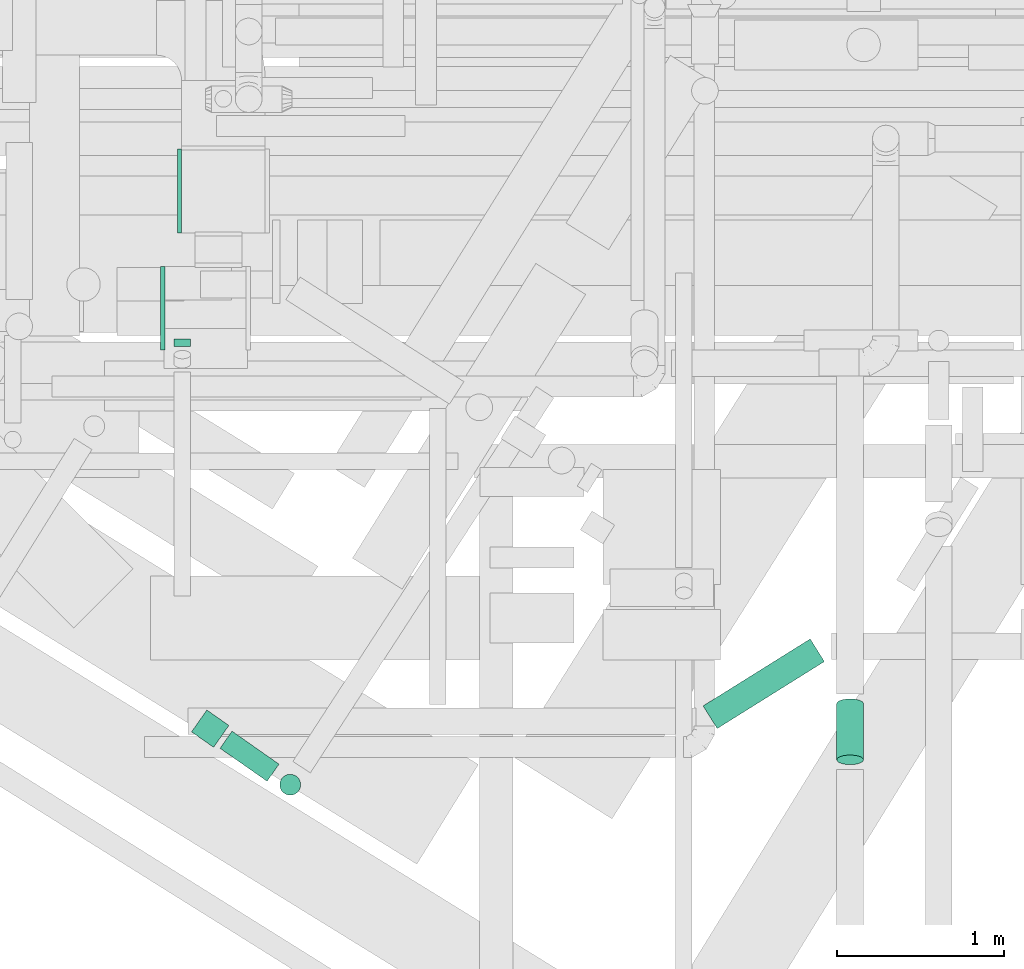
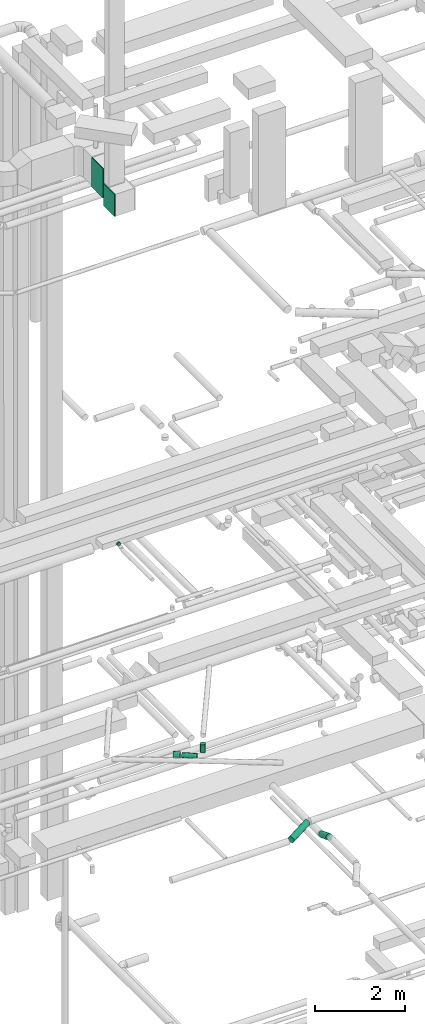
# One storey, part 94 of 337: 6 flow segments, 2 flow fittings.
"""IFC2X3 building model written with IfcOpenShell, lengths in millimetres."""

from ifc_helpers import new_model, entity, si_unit, converted_unit, derived_unit, direction, frame, origin, origin_2d_with_axis, place, context, subcontext, project, spatial, rectangle, circle, extrude, source, transform, mapped, material, type_object, type_shapes, element, save


model = new_model("IFC2X3")

# Units and contexts
model_context = context("Model", 3, precision=0.01, world=origin(), true_north=direction((6.12303176911189e-17, 1.0)))
body_context = subcontext(model_context, "Body", "Model", "MODEL_VIEW")
ifc_project = project(units=[si_unit("LENGTHUNIT", "METRE", prefix="MILLI"), si_unit("AREAUNIT", "SQUARE_METRE"), si_unit("VOLUMEUNIT", "CUBIC_METRE"), converted_unit("PLANEANGLEUNIT", "DEGREE", entity("IfcRatioMeasure", 0.0174532925199433), si_unit("PLANEANGLEUNIT", "RADIAN"), dimensions=[0, 0, 0, 0, 0, 0, 0]), si_unit("MASSUNIT", "GRAM", prefix="KILO"), derived_unit("MASSDENSITYUNIT", [(si_unit("MASSUNIT", "GRAM", prefix="KILO"), 1), (si_unit("LENGTHUNIT", "METRE"), -3)]), derived_unit("MOMENTOFINERTIAUNIT", [(si_unit("LENGTHUNIT", "METRE"), 4)]), si_unit("TIMEUNIT", "SECOND"), si_unit("FREQUENCYUNIT", "HERTZ"), si_unit("THERMODYNAMICTEMPERATUREUNIT", "DEGREE_CELSIUS"), derived_unit("THERMALTRANSMITTANCEUNIT", [(si_unit("MASSUNIT", "GRAM", prefix="KILO"), 1), (si_unit("THERMODYNAMICTEMPERATUREUNIT", "KELVIN"), -1), (si_unit("TIMEUNIT", "SECOND"), -3)]), derived_unit("VOLUMETRICFLOWRATEUNIT", [(si_unit("LENGTHUNIT", "METRE"), 3), (si_unit("TIMEUNIT", "SECOND"), -1)]), derived_unit("MASSFLOWRATEUNIT", [(si_unit("MASSUNIT", "GRAM", prefix="KILO"), 1), (si_unit("TIMEUNIT", "SECOND"), -1)]), derived_unit("ROTATIONALFREQUENCYUNIT", [(si_unit("TIMEUNIT", "SECOND"), -1)]), si_unit("ELECTRICCURRENTUNIT", "AMPERE"), si_unit("ELECTRICVOLTAGEUNIT", "VOLT"), si_unit("POWERUNIT", "WATT"), si_unit("FORCEUNIT", "NEWTON", prefix="KILO"), si_unit("ILLUMINANCEUNIT", "LUX"), si_unit("LUMINOUSFLUXUNIT", "LUMEN"), si_unit("LUMINOUSINTENSITYUNIT", "CANDELA"), derived_unit("USERDEFINED", [(si_unit("MASSUNIT", "GRAM", prefix="KILO"), -1), (si_unit("LENGTHUNIT", "METRE"), -2), (si_unit("TIMEUNIT", "SECOND"), 3), (si_unit("LUMINOUSFLUXUNIT", "LUMEN"), 1)]), derived_unit("LINEARVELOCITYUNIT", [(si_unit("LENGTHUNIT", "METRE"), 1), (si_unit("TIMEUNIT", "SECOND"), -1)]), si_unit("PRESSUREUNIT", "PASCAL"), derived_unit("USERDEFINED", [(si_unit("LENGTHUNIT", "METRE"), -2), (si_unit("MASSUNIT", "GRAM", prefix="KILO"), 1), (si_unit("TIMEUNIT", "SECOND"), -2)]), derived_unit("LINEARFORCEUNIT", [(si_unit("MASSUNIT", "GRAM", prefix="KILO"), 1), (si_unit("LENGTHUNIT", "METRE"), 1), (si_unit("TIMEUNIT", "SECOND"), -2), (si_unit("LENGTHUNIT", "METRE"), -1)]), derived_unit("PLANARFORCEUNIT", [(si_unit("MASSUNIT", "GRAM", prefix="KILO"), 1), (si_unit("LENGTHUNIT", "METRE"), 1), (si_unit("TIMEUNIT", "SECOND"), -2), (si_unit("LENGTHUNIT", "METRE"), -2)])], contexts=[model_context])

# Site, building, storey
site_placement = place(None, origin())
site = spatial("IfcSite", under=ifc_project, at=site_placement, CompositionType="ELEMENT")
building_placement = place(site_placement, origin())
building = spatial("IfcBuilding", under=site, at=building_placement, CompositionType="ELEMENT")
storey_placement = place(building_placement, origin())
storey = spatial("IfcBuildingStorey", under=building, at=storey_placement, CompositionType="ELEMENT", Elevation=0.0)

# Flow segments
duct_segment_type = type_object("IfcDuctSegmentType", PredefinedType="NOTDEFINED")
flow_segment_1_placement = place(storey_placement, frame((13237.87, 8547.84, 11368.4)))
element("IfcFlowSegment", 1, at=flow_segment_1_placement, inside=storey, type_object=duct_segment_type, context=body_context, shape_type="SweptSolid", body=[
    extrude(circle(Radius=80.0, at=origin_2d_with_axis()), frame((43.99, 69.44, 81.6), z_axis=(0.848048096156351, 0.529919264233325, 0.0), x_axis=(-0.529919264233325, 0.848048096156351, 0.0)), (0.0, 0.0, 1.0), 754.691066333196),
])
flow_segment_2_placement = place(storey_placement, frame((10351.98, 8233.32, 14785.9)))
element("IfcFlowSegment", 2, at=flow_segment_2_placement, inside=storey, type_object=duct_segment_type, context=body_context, shape_type="SweptSolid", body=[
    extrude(circle(Radius=62.5, at=origin_2d_with_axis()), frame((37.44, 249.56, 64.1), z_axis=(0.819152044288949, -0.573576436351108, 0.0), x_axis=(0.573576436351108, 0.819152044288949, 0.0)), (0.0, 0.0, 1.0), 343.059916885626),
])
flow_segment_3_placement = place(storey_placement, frame((10181.51, 8435.83, 14768.4)))
element("IfcFlowSegment", 3, at=flow_segment_3_placement, inside=storey, type_object=duct_segment_type, context=body_context, shape_type="SweptSolid", body=[
    extrude(circle(Radius=80.0, at=origin_2d_with_axis()), frame((179.25, 67.13, 81.6), z_axis=(-0.819152044288997, 0.573576436351039, 0.0), x_axis=(0.573576436351039, 0.819152044288997, 0.0)), (0.0, 0.0, 1.0), 160.855843276568),
])
flow_segment_4_placement = place(storey_placement, frame((14036.34, 8332.63, 11184.35)))
element("IfcFlowSegment", 4, at=flow_segment_4_placement, inside=storey, type_object=duct_segment_type, context=body_context, shape_type="SweptSolid", body=[
    extrude(circle(Radius=80.0, at=origin_2d_with_axis()), frame((81.6, 365.66, 76.28), z_axis=(0.0, -0.933580426497201, 0.358367949545302), x_axis=(-1.0, 0.0, 0.0)), (0.0, 0.0, 1.0), 359.255722065706),
])
flow_segment_5_placement = place(storey_placement, frame((10708.83, 8150.41, 14975.0)))
element("IfcFlowSegment", 5, at=flow_segment_5_placement, inside=storey, type_object=duct_segment_type, context=body_context, shape_type="SweptSolid", body=[
    extrude(circle(Radius=62.5, at=origin_2d_with_axis()), frame((64.01, 64.01, 0.0), z_axis=(0.0, 0.0, 1.0), x_axis=(-0.838670567945423, 0.544639035015029, 0.0)), (0.0, 0.0, 1.0), 225.000000000001),
])
flow_segment_6_placement = place(storey_placement, frame((10077.02, 10833.57, 19206.71)))
element("IfcFlowSegment", 6, at=flow_segment_6_placement, inside=storey, type_object=duct_segment_type, context=body_context, shape_type="SweptSolid", body=[
    extrude(circle(Radius=50.0, at=origin_2d_with_axis()), frame((51.6, 0.0, 51.6), z_axis=(0.0, 1.0, 0.0), x_axis=(-1.0, 0.0, 0.0)), (0.0, 0.0, 1.0), 43.1888646801333),
])

# Flow fittings
ifc_material = material()
duct_fitting_type_1 = type_object("IfcDuctFittingType", PredefinedType="NOTDEFINED", material=ifc_material)
shared_shape_1 = source(origin(), body_context, "Body", "SweptSolid", [
    extrude(rectangle(XDim=24.9999999999999, YDim=500.0, at=origin_2d_with_axis()), frame((12.5, 0.0, -400.0)), (0.0, 0.0, 1.0), 800.0),
])
type_shapes(duct_fitting_type_1, [shared_shape_1])
flow_fitting_1_placement = place(storey_placement, frame((10123.64, 11761.11, 28700.0), z_axis=(0.0, 0.0, 1.0), x_axis=(-1.0, 0.0, 0.0)))
element("IfcFlowFitting", 7, at=flow_fitting_1_placement, inside=storey, type_object=duct_fitting_type_1, material=ifc_material, context=body_context, shape_type="MappedRepresentation", body=[
    mapped(shared_shape_1, transform((0.0, 0.0, 0.0), scale=1.0)),
])
duct_fitting_type_2 = type_object("IfcDuctFittingType", PredefinedType="NOTDEFINED", material=ifc_material)
shared_shape_2 = source(origin(), body_context, "Body", "SweptSolid", [
    extrude(rectangle(XDim=24.9999999999999, YDim=500.0, at=origin_2d_with_axis()), frame((12.5, 0.0, -300.0)), (0.0, 0.0, 1.0), 600.0),
])
type_shapes(duct_fitting_type_2, [shared_shape_2])
flow_fitting_2_placement = place(storey_placement, frame((10023.38, 11061.11, 28550.0), z_axis=(0.0, 0.0, 1.0), x_axis=(-1.0, 0.0, 0.0)))
element("IfcFlowFitting", 8, at=flow_fitting_2_placement, inside=storey, type_object=duct_fitting_type_2, material=ifc_material, context=body_context, shape_type="MappedRepresentation", body=[
    mapped(shared_shape_2, transform((0.0, 0.0, 0.0), scale=1.0)),
])

save(model, "model.ifc")
